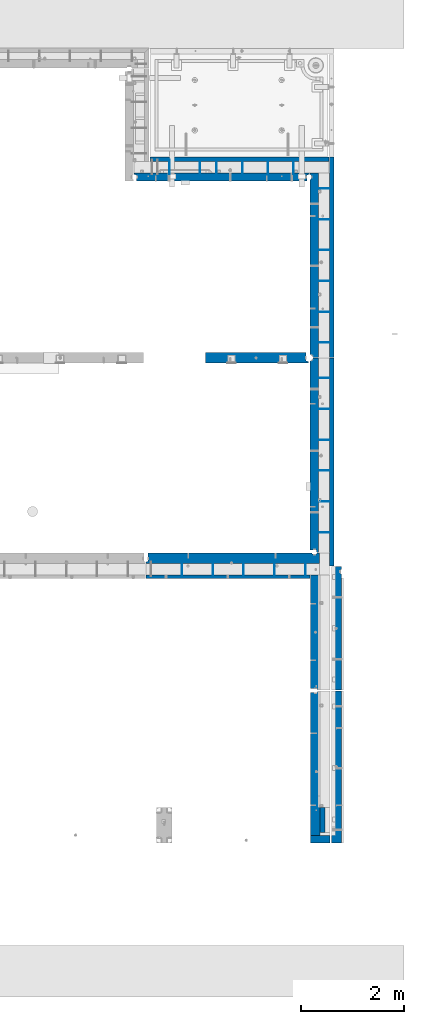
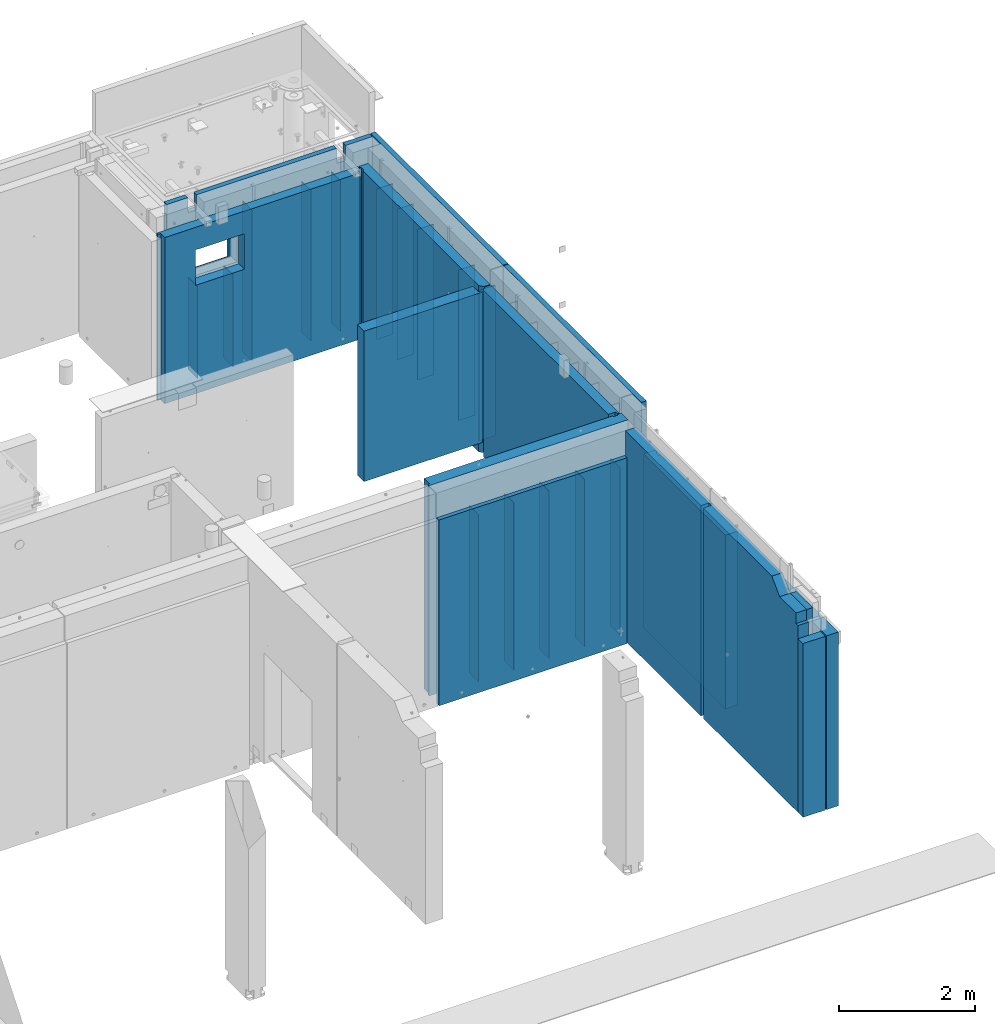
# One storey, part 178 of 264: 38 walls, 9 elements without a shape of their own.
"""IFC2X3 building model written with IfcOpenShell, lengths in millimetres."""

from ifc_helpers import new_model, si_unit, frame, origin_with_axes, place, context, subcontext, project, spatial, faceted_brep, material, type_object, element, aggregate, save


model = new_model("IFC2X3")

# Units and contexts
model_context = context("Model", 3, precision=1e-05, world=origin_with_axes())
body_context = subcontext(model_context, "Body", "Model", "MODEL_VIEW")
ifc_project = project(units=[si_unit("LENGTHUNIT", "METRE", prefix="MILLI"), si_unit("AREAUNIT", "SQUARE_METRE"), si_unit("VOLUMEUNIT", "CUBIC_METRE"), si_unit("MASSUNIT", "GRAM", prefix="KILO"), si_unit("TIMEUNIT", "SECOND"), si_unit("PLANEANGLEUNIT", "RADIAN"), si_unit("SOLIDANGLEUNIT", "STERADIAN"), si_unit("THERMODYNAMICTEMPERATUREUNIT", "DEGREE_CELSIUS"), si_unit("LUMINOUSINTENSITYUNIT", "LUMEN")], contexts=[model_context])

# Site, building, storey
site_placement = place(None, origin_with_axes())
site = spatial("IfcSite", under=ifc_project, at=site_placement, CompositionType="ELEMENT")
building_placement = place(site_placement, origin_with_axes())
building = spatial("IfcBuilding", under=site, at=building_placement, CompositionType="ELEMENT")
storey_placement = place(building_placement, origin_with_axes())
storey = spatial("IfcBuildingStorey", under=building, at=storey_placement, Name="K", CompositionType="ELEMENT", Elevation=0.0)

# Assembly, walls
assembly_1_placement = place(storey_placement, origin_with_axes())
assembly_1 = element("IfcElementAssembly", 1, at=assembly_1_placement, inside=storey, AssemblyPlace="NOTDEFINED", PredefinedType="REINFORCEMENT_UNIT")
ifc_material_1 = material(Name="Undefined")
wall_type_1 = type_object("IfcWallType", PredefinedType="NOTDEFINED")
wall_1_placement = place(assembly_1_placement, frame((32405.0062229193, 12730.0010506694, 79360.0), z_axis=(0.0, 0.0, 1.0), x_axis=(0.0, 1.0, 0.0)))
wall_1 = element("IfcWall", 2, at=wall_1_placement, type_object=wall_type_1, material=ifc_material_1, Name="(PD)", context=body_context, shape_type="Brep", body=[
    faceted_brep([(0.0, 4.99999999999909, -1500.0), (0.0, 4.99999999999909, 1500.0), (280.000000000024, 5.0, 1500.0), (280.000000000024, 5.0, -1500.0), (0.0, -5.00000000000091, 1500.0), (280.000000000025, -5.0, 1500.0), (0.0, -5.00000000000091, -1500.0), (280.000000000025, -5.0, -1500.0)], [[[0, 1, 2, 3]], [[1, 4, 5, 2]], [[4, 6, 7, 5]], [[6, 0, 3, 7]], [[5, 7, 3, 2]], [[6, 4, 1, 0]]]),
])
wall_2_placement = place(assembly_1_placement, frame((33005.0062229194, 12730.0010506694, 79360.0), z_axis=(0.0, 0.0, 1.0), x_axis=(0.0, 1.0, 0.0)))
wall_2 = element("IfcWall", 3, at=wall_2_placement, type_object=wall_type_1, material=ifc_material_1, Name="(PD)", context=body_context, shape_type="Brep", body=[
    faceted_brep([(0.0, 4.99999999999909, -1500.0), (0.0, 4.99999999999909, 1500.0), (280.000000000024, 5.0, 1500.0), (280.000000000024, 5.0, -1500.0), (0.0, -5.00000000000091, 1500.0), (280.000000000025, -5.0, 1500.0), (0.0, -5.00000000000091, -1500.0), (280.000000000025, -5.0, -1500.0)], [[[0, 1, 2, 3]], [[1, 4, 5, 2]], [[4, 6, 7, 5]], [[6, 0, 3, 7]], [[5, 7, 3, 2]], [[6, 4, 1, 0]]]),
])
wall_3_placement = place(assembly_1_placement, frame((33605.0062229194, 12730.0010506694, 79360.0), z_axis=(0.0, 0.0, 1.0), x_axis=(0.0, 1.0, 0.0)))
wall_3 = element("IfcWall", 4, at=wall_3_placement, type_object=wall_type_1, material=ifc_material_1, Name="(PD)", context=body_context, shape_type="Brep", body=[
    faceted_brep([(0.0, 4.99999999999909, -1500.0), (0.0, 4.99999999999909, 1500.0), (280.000000000024, 5.0, 1500.0), (280.000000000024, 5.0, -1500.0), (0.0, -5.00000000000091, 1500.0), (280.000000000025, -5.0, 1500.0), (0.0, -5.00000000000091, -1500.0), (280.000000000025, -5.0, -1500.0)], [[[0, 1, 2, 3]], [[1, 4, 5, 2]], [[4, 6, 7, 5]], [[6, 0, 3, 7]], [[5, 7, 3, 2]], [[6, 4, 1, 0]]]),
])
wall_4_placement = place(assembly_1_placement, frame((34205.0062229194, 12730.0010506694, 79360.0), z_axis=(0.0, 0.0, 1.0), x_axis=(0.0, 1.0, 0.0)))
wall_4 = element("IfcWall", 5, at=wall_4_placement, type_object=wall_type_1, material=ifc_material_1, Name="(PD)", context=body_context, shape_type="Brep", body=[
    faceted_brep([(0.0, 4.99999999999909, -1500.0), (0.0, 4.99999999999909, 1500.0), (280.000000000024, 5.0, 1500.0), (280.000000000024, 5.0, -1500.0), (0.0, -5.00000000000091, 1500.0), (280.000000000025, -5.0, 1500.0), (0.0, -5.00000000000091, -1500.0), (280.000000000025, -5.0, -1500.0)], [[[0, 1, 2, 3]], [[1, 4, 5, 2]], [[4, 6, 7, 5]], [[6, 0, 3, 7]], [[5, 7, 3, 2]], [[6, 4, 1, 0]]]),
])
wall_5_placement = place(assembly_1_placement, frame((34805.0062229194, 12730.0010506694, 79360.0), z_axis=(0.0, 0.0, 1.0), x_axis=(0.0, 1.0, 0.0)))
wall_5 = element("IfcWall", 6, at=wall_5_placement, type_object=wall_type_1, material=ifc_material_1, Name="(PD)", context=body_context, shape_type="Brep", body=[
    faceted_brep([(0.0, 4.99999999999909, -1500.0), (0.0, 4.99999999999909, 1500.0), (280.000000000024, 5.0, 1500.0), (280.000000000024, 5.0, -1500.0), (0.0, -5.00000000000091, 1500.0), (280.000000000025, -5.0, 1500.0), (0.0, -5.00000000000091, -1500.0), (280.000000000025, -5.0, -1500.0)], [[[0, 1, 2, 3]], [[1, 4, 5, 2]], [[4, 6, 7, 5]], [[6, 0, 3, 7]], [[5, 7, 3, 2]], [[6, 4, 1, 0]]]),
])

# Assembly, wall
assembly_2_placement = place(storey_placement, origin_with_axes())
assembly_2 = element("IfcElementAssembly", 7, at=assembly_2_placement, inside=storey, AssemblyPlace="NOTDEFINED", PredefinedType="REINFORCEMENT_UNIT")
ifc_material_2 = material(Name="CONCRETE/C30/37")
wall_type_2 = type_object("IfcWallType", PredefinedType="NOTDEFINED")
wall_6_placement = place(assembly_2_placement, frame((35140.0024573139, 8230.00189658467, 79470.0), z_axis=(0.0, 0.0, 1.0), x_axis=(0.0, -1.0, 0.0)))
wall_6 = element("IfcWall", 8, at=wall_6_placement, type_object=wall_type_2, material=ifc_material_2, context=body_context, shape_type="Brep", body=[
    faceted_brep([(0.0, 50.0, -1770.0), (0.0, 50.0, 1770.0), (479.99999999992, 50.0, 1770.0), (479.99999999992, 50.0, -1770.0), (0.0, -50.0, 1770.0), (479.99999999992, -50.0, 1770.0), (0.0, -50.0, -1770.0), (479.99999999992, -50.0, -1770.0)], [[[0, 1, 2, 3]], [[1, 4, 5, 2]], [[4, 6, 7, 5]], [[6, 0, 3, 7]], [[5, 7, 3, 2]], [[6, 4, 1, 0]]]),
])

assembly_3_placement = place(storey_placement, origin_with_axes())
assembly_3 = element("IfcElementAssembly", 9, at=assembly_3_placement, inside=storey, AssemblyPlace="NOTDEFINED", PredefinedType="REINFORCEMENT_UNIT")
ifc_material_3 = material(Name="CONCRETE/C35/45")
wall_type_3 = type_object("IfcWallType", PredefinedType="NOTDEFINED")
wall_7_placement = place(assembly_3_placement, frame((35410.0000014901, 10499.9996549055, 79257.5030770672), z_axis=(0.0, 0.0, 1.0), x_axis=(0.0, -1.0, 0.0)))
wall_7 = element("IfcWall", 10, at=wall_7_placement, type_object=wall_type_3, material=ifc_material_3, context=body_context, shape_type="Brep", body=[
    faceted_brep([(0.0, 100.0, -1557.5), (0.0, 100.0, 1557.5), (2954.98965490548, 100.0, 1557.5), (2954.98965490548, 100.0, -1557.5), (0.0, -100.0, 1557.5), (2954.98965490548, -100.0, 1557.5), (0.0, -100.0, -1557.5), (2954.98965490548, -100.0, -1557.5)], [[[0, 1, 2, 3]], [[1, 4, 5, 2]], [[4, 6, 7, 5]], [[6, 0, 3, 7]], [[5, 7, 3, 2]], [[6, 4, 1, 0]]]),
])
aggregate(assembly_3, [wall_7])

assembly_4_placement = place(storey_placement, origin_with_axes())
assembly_4 = element("IfcElementAssembly", 11, at=assembly_4_placement, inside=storey, AssemblyPlace="NOTDEFINED", PredefinedType="REINFORCEMENT_UNIT")
wall_8_placement = place(assembly_4_placement, frame((35410.0000014901, 12919.9896549055, 79257.5030770672), z_axis=(0.0, 0.0, 1.0), x_axis=(0.0, -1.0, 0.0)))
wall_8 = element("IfcWall", 12, at=wall_8_placement, type_object=wall_type_3, material=ifc_material_3, context=body_context, shape_type="Brep", body=[
    faceted_brep([(149.999653415372, 100.0, 1557.5), (149.999653415372, 100.0, -1557.5), (136.999653415371, 80.0, -1557.5), (136.999653415371, 80.0, 1557.5), (62.9996534153706, 80.0, -1557.5), (62.9996534153706, 80.0, 1557.5), (49.999653415367, 100.0, 1557.5), (49.999653415367, 100.0, -1557.5), (2404.98965490548, -100.0, 1557.5), (2404.98965490548, -100.0, -1557.5), (2404.98965490548, 100.0, -1557.5), (2404.98965490548, 100.0, 1557.5), (-0.000346584629369318, -100.0, 1557.5), (-0.000346584629369318, -100.0, -1557.5), (-0.000346584629369318, 100.0, 1557.5), (-0.000346584629369318, 100.0, -1557.5)], [[[0, 1, 2, 3]], [[3, 2, 4, 5]], [[6, 5, 4, 7]], [[8, 9, 10, 11]], [[12, 13, 9, 8]], [[13, 12, 14, 15]], [[15, 14, 6, 7]], [[2, 1, 10, 9, 13, 15, 7, 4]], [[11, 10, 1, 0]], [[14, 12, 8, 11, 0, 3, 5, 6]]]),
])
aggregate(assembly_4, [wall_8])

# Assembly, walls
assembly_5_placement = place(storey_placement, origin_with_axes())
assembly_5 = element("IfcElementAssembly", 13, at=assembly_5_placement, inside=storey, AssemblyPlace="NOTDEFINED", PredefinedType="REINFORCEMENT_UNIT")
wall_type_4 = type_object("IfcWallType", PredefinedType="NOTDEFINED")
wall_9_placement = place(assembly_5_placement, frame((32759.9902441406, 20549.9951872276, 79465.0), z_axis=(0.0, 0.0, 1.0), x_axis=(0.0, 1.0, 0.0)))
wall_9 = element("IfcWall", 14, at=wall_9_placement, type_object=wall_type_4, material=ifc_material_1, Name="(PD)", context=body_context, shape_type="Brep", body=[
    faceted_brep([(0.0, 5.0, -825.0), (0.0, 5.0, 825.0), (280.0, 5.0, 825.0), (280.0, 5.0, -825.0), (0.0, -5.0, 825.0), (280.0, -5.0, 825.0), (0.0, -5.0, -825.0), (280.0, -5.0, -825.0)], [[[0, 1, 2, 3]], [[1, 4, 5, 2]], [[4, 6, 7, 5]], [[6, 0, 3, 7]], [[5, 7, 3, 2]], [[6, 4, 1, 0]]]),
])
wall_10_placement = place(assembly_5_placement, frame((32159.9902441406, 20549.9951872276, 79465.0), z_axis=(0.0, 0.0, 1.0), x_axis=(0.0, 1.0, 0.0)))
wall_10 = element("IfcWall", 15, at=wall_10_placement, type_object=wall_type_4, material=ifc_material_1, Name="(PD)", context=body_context, shape_type="Brep", body=[
    faceted_brep([(0.0, 5.0, -825.0), (0.0, 5.0, 825.0), (280.0, 5.0, 825.0), (280.0, 5.0, -825.0), (0.0, -5.0, 825.0), (280.0, -5.0, 825.0), (0.0, -5.0, -825.0), (280.0, -5.0, -825.0)], [[[0, 1, 2, 3]], [[1, 4, 5, 2]], [[4, 6, 7, 5]], [[6, 0, 3, 7]], [[5, 7, 3, 2]], [[6, 4, 1, 0]]]),
])
wall_type_5 = type_object("IfcWallType", PredefinedType="NOTDEFINED")
wall_11_placement = place(assembly_5_placement, frame((34579.9902441406, 20549.9951872276, 79990.0), z_axis=(0.0, 0.0, 1.0), x_axis=(0.0, 1.0, 0.0)))
wall_11 = element("IfcWall", 16, at=wall_11_placement, type_object=wall_type_5, material=ifc_material_1, Name="(PD)", context=body_context, shape_type="Brep", body=[
    faceted_brep([(0.0, 5.0, -1350.0), (0.0, 5.0, 1350.0), (280.0, 5.0, 1350.0), (280.0, 5.0, -1350.0), (0.0, -5.0, 1350.0), (280.0, -5.0, 1350.0), (0.0, -5.0, -1350.0), (280.0, -5.0, -1350.0)], [[[0, 1, 2, 3]], [[1, 4, 5, 2]], [[4, 6, 7, 5]], [[6, 0, 3, 7]], [[5, 7, 3, 2]], [[6, 4, 1, 0]]]),
])
wall_12_placement = place(assembly_5_placement, frame((34079.9902441406, 20549.9951872276, 79990.0), z_axis=(0.0, 0.0, 1.0), x_axis=(0.0, 1.0, 0.0)))
wall_12 = element("IfcWall", 17, at=wall_12_placement, type_object=wall_type_5, material=ifc_material_1, Name="(PD)", context=body_context, shape_type="Brep", body=[
    faceted_brep([(0.0, 5.0, -1350.0), (0.0, 5.0, 1350.0), (280.0, 5.0, 1350.0), (280.0, 5.0, -1350.0), (0.0, -5.0, 1350.0), (280.0, -5.0, 1350.0), (0.0, -5.0, -1350.0), (280.0, -5.0, -1350.0)], [[[0, 1, 2, 3]], [[1, 4, 5, 2]], [[4, 6, 7, 5]], [[6, 0, 3, 7]], [[5, 7, 3, 2]], [[6, 4, 1, 0]]]),
])
wall_13_placement = place(assembly_5_placement, frame((33579.9902441406, 20549.9951872276, 79990.0), z_axis=(0.0, 0.0, 1.0), x_axis=(0.0, 1.0, 0.0)))
wall_13 = element("IfcWall", 18, at=wall_13_placement, type_object=wall_type_5, material=ifc_material_1, Name="(PD)", context=body_context, shape_type="Brep", body=[
    faceted_brep([(0.0, 5.0, -1350.0), (0.0, 5.0, 1350.0), (280.0, 5.0, 1350.0), (280.0, 5.0, -1350.0), (0.0, -5.0, 1350.0), (280.0, -5.0, 1350.0), (0.0, -5.0, -1350.0), (280.0, -5.0, -1350.0)], [[[0, 1, 2, 3]], [[1, 4, 5, 2]], [[4, 6, 7, 5]], [[6, 0, 3, 7]], [[5, 7, 3, 2]], [[6, 4, 1, 0]]]),
])

assembly_6_placement = place(storey_placement, origin_with_axes())
assembly_6 = element("IfcElementAssembly", 19, at=assembly_6_placement, inside=storey, AssemblyPlace="NOTDEFINED", PredefinedType="REINFORCEMENT_UNIT")
wall_14_placement = place(assembly_6_placement, frame((35310.0033032291, 13584.9956621903, 79990.0), z_axis=(0.0, 0.0, 1.0), x_axis=(-1.0, 3.00000001838171e-08, 0.0)))
wall_14 = element("IfcWall", 20, at=wall_14_placement, type_object=wall_type_5, material=ifc_material_1, Name="(PD)", context=body_context, shape_type="Brep", body=[
    faceted_brep([(0.0, 5.0, -1350.0), (0.0, 5.0, 1350.0), (280.0, 5.0, 1350.0), (280.0, 5.0, -1350.0), (0.0, -5.0, 1350.0), (280.0, -5.0, 1350.0), (0.0, -5.0, -1350.0), (280.0, -5.0, -1350.0)], [[[0, 1, 2, 3]], [[1, 4, 5, 2]], [[4, 6, 7, 5]], [[6, 0, 3, 7]], [[5, 7, 3, 2]], [[6, 4, 1, 0]]]),
])
wall_15_placement = place(assembly_6_placement, frame((35310.0033032291, 14184.9956621903, 79990.0), z_axis=(0.0, 0.0, 1.0), x_axis=(-1.0, 3.00000001838171e-08, 0.0)))
wall_15 = element("IfcWall", 21, at=wall_15_placement, type_object=wall_type_5, material=ifc_material_1, Name="(PD)", context=body_context, shape_type="Brep", body=[
    faceted_brep([(0.0, 5.0, -1350.0), (0.0, 5.0, 1350.0), (280.0, 5.0, 1350.0), (280.0, 5.0, -1350.0), (0.0, -5.0, 1350.0), (280.0, -5.0, 1350.0), (0.0, -5.0, -1350.0), (280.0, -5.0, -1350.0)], [[[0, 1, 2, 3]], [[1, 4, 5, 2]], [[4, 6, 7, 5]], [[6, 0, 3, 7]], [[5, 7, 3, 2]], [[6, 4, 1, 0]]]),
])
wall_16_placement = place(assembly_6_placement, frame((35310.0033032291, 14784.9956621903, 79990.0), z_axis=(0.0, 0.0, 1.0), x_axis=(-1.0, 3.00000001838171e-08, 0.0)))
wall_16 = element("IfcWall", 22, at=wall_16_placement, type_object=wall_type_5, material=ifc_material_1, Name="(PD)", context=body_context, shape_type="Brep", body=[
    faceted_brep([(0.0, 5.0, -1350.0), (0.0, 5.0, 1350.0), (280.0, 5.0, 1350.0), (280.0, 5.0, -1350.0), (0.0, -5.0, 1350.0), (280.0, -5.0, 1350.0), (0.0, -5.0, -1350.0), (280.0, -5.0, -1350.0)], [[[0, 1, 2, 3]], [[1, 4, 5, 2]], [[4, 6, 7, 5]], [[6, 0, 3, 7]], [[5, 7, 3, 2]], [[6, 4, 1, 0]]]),
])
wall_17_placement = place(assembly_6_placement, frame((35310.0033032291, 15384.9956621903, 79990.0), z_axis=(0.0, 0.0, 1.0), x_axis=(-1.0, 3.00000001838171e-08, 0.0)))
wall_17 = element("IfcWall", 23, at=wall_17_placement, type_object=wall_type_5, material=ifc_material_1, Name="(PD)", context=body_context, shape_type="Brep", body=[
    faceted_brep([(0.0, 5.0, -1350.0), (0.0, 5.0, 1350.0), (280.0, 5.0, 1350.0), (280.0, 5.0, -1350.0), (0.0, -5.0, 1350.0), (280.0, -5.0, 1350.0), (0.0, -5.0, -1350.0), (280.0, -5.0, -1350.0)], [[[0, 1, 2, 3]], [[1, 4, 5, 2]], [[4, 6, 7, 5]], [[6, 0, 3, 7]], [[5, 7, 3, 2]], [[6, 4, 1, 0]]]),
])
wall_18_placement = place(assembly_6_placement, frame((35310.0033032291, 15984.9956621903, 79990.0), z_axis=(0.0, 0.0, 1.0), x_axis=(-1.0, 3.00000001838171e-08, 0.0)))
wall_18 = element("IfcWall", 24, at=wall_18_placement, type_object=wall_type_5, material=ifc_material_1, Name="(PD)", context=body_context, shape_type="Brep", body=[
    faceted_brep([(0.0, 5.0, -1350.0), (0.0, 5.0, 1350.0), (280.0, 5.0, 1350.0), (280.0, 5.0, -1350.0), (0.0, -5.0, 1350.0), (280.0, -5.0, 1350.0), (0.0, -5.0, -1350.0), (280.0, -5.0, -1350.0)], [[[0, 1, 2, 3]], [[1, 4, 5, 2]], [[4, 6, 7, 5]], [[6, 0, 3, 7]], [[5, 7, 3, 2]], [[6, 4, 1, 0]]]),
])
wall_19_placement = place(assembly_6_placement, frame((35310.0033032291, 16584.9956621903, 79990.0), z_axis=(0.0, 0.0, 1.0), x_axis=(-1.0, 3.00000001838171e-08, 0.0)))
wall_19 = element("IfcWall", 25, at=wall_19_placement, type_object=wall_type_5, material=ifc_material_1, Name="(PD)", context=body_context, shape_type="Brep", body=[
    faceted_brep([(0.0, 5.0, -1350.0), (0.0, 5.0, 1350.0), (280.0, 5.0, 1350.0), (280.0, 5.0, -1350.0), (0.0, -5.0, 1350.0), (280.0, -5.0, 1350.0), (0.0, -5.0, -1350.0), (280.0, -5.0, -1350.0)], [[[0, 1, 2, 3]], [[1, 4, 5, 2]], [[4, 6, 7, 5]], [[6, 0, 3, 7]], [[5, 7, 3, 2]], [[6, 4, 1, 0]]]),
])

assembly_7_placement = place(storey_placement, origin_with_axes())
assembly_7 = element("IfcElementAssembly", 26, at=assembly_7_placement, inside=storey, AssemblyPlace="NOTDEFINED", PredefinedType="REINFORCEMENT_UNIT")
wall_20_placement = place(assembly_7_placement, frame((35310.0033032291, 17274.9956621903, 79855.0), z_axis=(0.0, 0.0, 1.0), x_axis=(-1.0, 3.00000001838171e-08, 0.0)))
wall_20 = element("IfcWall", 27, at=wall_20_placement, type_object=wall_type_5, material=ifc_material_1, Name="(PD)", context=body_context, shape_type="Brep", body=[
    faceted_brep([(0.0, 5.0, -1350.0), (0.0, 5.0, 1350.0), (280.0, 5.0, 1350.0), (280.0, 5.0, -1350.0), (0.0, -5.0, 1350.0), (280.0, -5.0, 1350.0), (0.0, -5.0, -1350.0), (280.0, -5.0, -1350.0)], [[[0, 1, 2, 3]], [[1, 4, 5, 2]], [[4, 6, 7, 5]], [[6, 0, 3, 7]], [[5, 7, 3, 2]], [[6, 4, 1, 0]]]),
])
wall_21_placement = place(assembly_7_placement, frame((35310.0033032291, 17874.9956621903, 79855.0), z_axis=(0.0, 0.0, 1.0), x_axis=(-1.0, 3.00000001838171e-08, 0.0)))
wall_21 = element("IfcWall", 28, at=wall_21_placement, type_object=wall_type_5, material=ifc_material_1, Name="(PD)", context=body_context, shape_type="Brep", body=[
    faceted_brep([(0.0, 5.0, -1350.0), (0.0, 5.0, 1350.0), (280.0, 5.0, 1350.0), (280.0, 5.0, -1350.0), (0.0, -5.0, 1350.0), (280.0, -5.0, 1350.0), (0.0, -5.0, -1350.0), (280.0, -5.0, -1350.0)], [[[0, 1, 2, 3]], [[1, 4, 5, 2]], [[4, 6, 7, 5]], [[6, 0, 3, 7]], [[5, 7, 3, 2]], [[6, 4, 1, 0]]]),
])
wall_22_placement = place(assembly_7_placement, frame((35310.0033032291, 18474.9956621903, 79855.0), z_axis=(0.0, 0.0, 1.0), x_axis=(-1.0, 3.00000001838171e-08, 0.0)))
wall_22 = element("IfcWall", 29, at=wall_22_placement, type_object=wall_type_5, material=ifc_material_1, Name="(PD)", context=body_context, shape_type="Brep", body=[
    faceted_brep([(0.0, 5.0, -1350.0), (0.0, 5.0, 1350.0), (280.0, 5.0, 1350.0), (280.0, 5.0, -1350.0), (0.0, -5.0, 1350.0), (280.0, -5.0, 1350.0), (0.0, -5.0, -1350.0), (280.0, -5.0, -1350.0)], [[[0, 1, 2, 3]], [[1, 4, 5, 2]], [[4, 6, 7, 5]], [[6, 0, 3, 7]], [[5, 7, 3, 2]], [[6, 4, 1, 0]]]),
])
wall_23_placement = place(assembly_7_placement, frame((35310.0033032291, 19074.9956621903, 79855.0), z_axis=(0.0, 0.0, 1.0), x_axis=(-1.0, 3.00000001838171e-08, 0.0)))
wall_23 = element("IfcWall", 30, at=wall_23_placement, type_object=wall_type_5, material=ifc_material_1, Name="(PD)", context=body_context, shape_type="Brep", body=[
    faceted_brep([(0.0, 5.0, -1350.0), (0.0, 5.0, 1350.0), (280.0, 5.0, 1350.0), (280.0, 5.0, -1350.0), (0.0, -5.0, 1350.0), (280.0, -5.0, 1350.0), (0.0, -5.0, -1350.0), (280.0, -5.0, -1350.0)], [[[0, 1, 2, 3]], [[1, 4, 5, 2]], [[4, 6, 7, 5]], [[6, 0, 3, 7]], [[5, 7, 3, 2]], [[6, 4, 1, 0]]]),
])
wall_24_placement = place(assembly_7_placement, frame((35310.0033032291, 19674.9956621903, 79855.0), z_axis=(0.0, 0.0, 1.0), x_axis=(-1.0, 3.00000001838171e-08, 0.0)))
wall_24 = element("IfcWall", 31, at=wall_24_placement, type_object=wall_type_5, material=ifc_material_1, Name="(PD)", context=body_context, shape_type="Brep", body=[
    faceted_brep([(0.0, 5.0, -1350.0), (0.0, 5.0, 1350.0), (280.0, 5.0, 1350.0), (280.0, 5.0, -1350.0), (0.0, -5.0, 1350.0), (280.0, -5.0, 1350.0), (0.0, -5.0, -1350.0), (280.0, -5.0, -1350.0)], [[[0, 1, 2, 3]], [[1, 4, 5, 2]], [[4, 6, 7, 5]], [[6, 0, 3, 7]], [[5, 7, 3, 2]], [[6, 4, 1, 0]]]),
])
wall_25_placement = place(assembly_7_placement, frame((35310.0033032291, 20274.9956621903, 79855.0), z_axis=(0.0, 0.0, 1.0), x_axis=(-1.0, 3.00000001838171e-08, 0.0)))
wall_25 = element("IfcWall", 32, at=wall_25_placement, type_object=wall_type_5, material=ifc_material_1, Name="(PD)", context=body_context, shape_type="Brep", body=[
    faceted_brep([(0.0, 5.0, -1350.0), (0.0, 5.0, 1350.0), (280.0, 5.0, 1350.0), (280.0, 5.0, -1350.0), (0.0, -5.0, 1350.0), (280.0, -5.0, 1350.0), (0.0, -5.0, -1350.0), (280.0, -5.0, -1350.0)], [[[0, 1, 2, 3]], [[1, 4, 5, 2]], [[4, 6, 7, 5]], [[6, 0, 3, 7]], [[5, 7, 3, 2]], [[6, 4, 1, 0]]]),
])

# Wall
wall_26_placement = place(assembly_5_placement, frame((33079.9902441406, 20549.9951872276, 79990.0), z_axis=(0.0, 0.0, 1.0), x_axis=(0.0, 1.0, 0.0)))
wall_26 = element("IfcWall", 33, at=wall_26_placement, type_object=wall_type_5, material=ifc_material_1, Name="(PD)", context=body_context, shape_type="Brep", body=[
    faceted_brep([(0.0, 5.0, -1350.0), (0.0, 5.0, 1350.0), (280.0, 5.0, 1350.0), (280.0, 5.0, -1350.0), (0.0, -5.0, 1350.0), (280.0, -5.0, 1350.0), (0.0, -5.0, -1350.0), (280.0, -5.0, -1350.0)], [[[0, 1, 2, 3]], [[1, 4, 5, 2]], [[4, 6, 7, 5]], [[6, 0, 3, 7]], [[5, 7, 3, 2]], [[6, 4, 1, 0]]]),
])

wall_type_6 = type_object("IfcWallType", PredefinedType="NOTDEFINED")
wall_27_placement = place(assembly_6_placement, frame((35322.5000031936, 16975.0005124534, 80115.0), z_axis=(0.0, 0.0, 1.0), x_axis=(0.0, -1.0, 0.0)))
wall_27 = element("IfcWall", 34, at=wall_27_placement, type_object=wall_type_6, material=ifc_material_2, context=body_context, shape_type="Brep", body=[
    faceted_brep([(0.000294195302558364, 42.5000000000073, -1625.0), (0.000294195302558364, 42.5000000000073, 1625.0), (4040.00844965085, 42.5000000000073, 1625.0), (4040.00844965085, 42.5000000000073, -1625.0), (0.000242430302023422, -42.5, 1625.0), (4040.00844965085, -42.4999999999927, 1625.0), (0.000242430302023422, -42.5, -1625.0), (4040.00844965085, -42.4999999999927, -1625.0)], [[[0, 1, 2, 3]], [[1, 4, 5, 2]], [[4, 6, 7, 5]], [[6, 0, 3, 7]], [[5, 7, 3, 2]], [[6, 4, 1, 0]]]),
])

wall_28_placement = place(assembly_7_placement, frame((35322.5, 20885.0, 80115.0), z_axis=(0.0, 0.0, 1.0), x_axis=(0.0, -1.0, 0.0)))
wall_28 = element("IfcWall", 35, at=wall_28_placement, type_object=wall_type_6, material=ifc_material_2, context=body_context, shape_type="Brep", body=[
    faceted_brep([(0.0, 42.5000000000036, -1625.0), (0.0, 42.5000000000036, 1625.0), (3894.99975585938, 42.5, 1625.0), (3894.99975585938, 42.5, -1625.0), (3.63797880709171e-12, -42.4999999999964, 1625.0), (3894.99975585938, -42.5, 1625.0), (3.63797880709171e-12, -42.4999999999964, -1625.0), (3894.99975585938, -42.5, -1625.0)], [[[0, 1, 2, 3]], [[1, 4, 5, 2]], [[4, 6, 7, 5]], [[6, 0, 3, 7]], [[5, 7, 3, 2]], [[6, 4, 1, 0]]]),
])

wall_29_placement = place(assembly_5_placement, frame((31779.9952566975, 20842.5, 80115.0), z_axis=(0.0, 0.0, 1.0), x_axis=(1.0, 0.0, 0.0)))
wall_29 = element("IfcWall", 36, at=wall_29_placement, type_object=wall_type_6, material=ifc_material_2, context=body_context, shape_type="Brep", body=[
    faceted_brep([(2879.97819479133, 42.5, 1625.0), (2879.97819479133, -42.5, 1625.0), (2879.97819479133, -42.5, 1355.0), (2879.97819479133, 42.5, 1355.0), (3029.97819479133, -42.5, 1355.0), (3029.97819479133, 42.5, 1355.0), (3029.97819479133, 42.5, 1625.0), (3029.97819479133, -42.5, 1625.0), (504.978194791329, 42.5, 1625.0), (504.978194791329, -42.5, 1625.0), (504.978194791329, 42.5, 1355.0), (504.978194791329, -42.5, 1355.0), (354.978194791329, 42.5, 1355.0), (354.978194791329, -42.5, 1355.0), (354.978194791329, 42.5, 1625.0), (354.978194791329, -42.5, 1625.0), (0.0, 42.5000000000036, 1625.0), (3.63797880709171e-12, -42.4999999999964, 1625.0), (3.63797880709171e-12, -42.4999999999964, -1625.0), (0.0, 42.5000000000036, -1625.0), (3485.00474330254, 42.5, -1625.0), (3485.00474330254, -42.5, -1625.0), (3485.00474330254, -42.5, 1625.0), (3485.00474330254, 42.5, 1625.0), (1055.00306334562, -42.5, 325.0), (305.003063345623, -42.5, 325.0), (305.003063345623, -42.5, 915.0), (305.003063345623, -42.5, 920.0), (1055.00306334562, -42.5, 920.0), (1055.00306334562, -42.5, 915.0), (1065.00306334562, 42.5, 275.0), (1065.00306334562, 42.5, 915.0), (295.003063345623, 42.5, 275.0), (295.003063345623, 42.5, 915.0), (305.003063345623, 42.5, 915.0), (1055.00306334562, 42.5, 915.0)], [[[0, 1, 2, 3]], [[3, 2, 4, 5]], [[6, 5, 4, 7]], [[8, 9, 1, 0]], [[8, 10, 11, 9]], [[12, 13, 11, 10]], [[14, 15, 13, 12]], [[16, 17, 15, 14]], [[18, 17, 16, 19]], [[18, 19, 20, 21]], [[22, 21, 20, 23]], [[22, 23, 6, 7]], [[2, 1, 9, 11, 13, 15, 17, 18, 21, 22, 7, 4], [24, 25, 26, 27, 28, 29]], [[30, 24, 29, 28, 31]], [[32, 25, 24, 30]], [[26, 25, 32, 33, 27]], [[34, 35, 31, 28, 27, 33]], [[23, 20, 19, 16, 14, 12, 10, 8, 0, 3, 5, 6], [34, 33, 32, 30, 31, 35]]]),
])

ifc_material_4 = material(Name="CONCRETE/C25/30")
wall_type_7 = type_object("IfcWallType", PredefinedType="NOTDEFINED")
wall_30_placement = place(assembly_6_placement, frame((34980.0, 16980.0000452669, 79980.0), z_axis=(0.0, 0.0, 1.0), x_axis=(0.0, -1.0, 0.0)))
wall_30 = element("IfcWall", 37, at=wall_30_placement, type_object=wall_type_7, material=ifc_material_4, context=body_context, shape_type="Brep", body=[
    faceted_brep([(3734.99809692287, -80.0, 1490.0), (3734.99809692287, -80.0, -1490.0), (3734.9981726219, 37.0000420547076, -1490.0), (3734.9981726219, 37.0000420547076, 1490.0), (3784.99818103289, 50.0000097047014, 1490.0), (3784.99818103289, 50.0000097047014, -1490.0), (4.99978818623276, -20.0000000450164, 1490.0), (4.99978818623276, -20.0000000450164, -1490.0), (64.9997493662195, -80.0, -1490.0), (64.9997493662195, -80.0, 1490.0), (4.99985288623066, 80.0000000000073, 1490.0), (4.99985288623066, 80.0000000000073, -1490.0), (3784.99820044288, 80.0000000000146, 1490.0), (3784.99820044288, 80.0000000000146, -1490.0)], [[[0, 1, 2, 3]], [[4, 3, 2, 5]], [[6, 7, 8, 9]], [[10, 11, 7, 6]], [[11, 10, 12, 13]], [[13, 12, 4, 5]], [[1, 8, 7, 11, 13, 5, 2]], [[9, 8, 1, 0]], [[12, 10, 6, 9, 0, 3, 4]]]),
])

aggregate(assembly_6, [wall_14, wall_15, wall_16, wall_17, wall_18, wall_19, wall_27, wall_30])

wall_31_placement = place(assembly_7_placement, frame((34980.0, 20575.0, 79980.0), z_axis=(0.0, 0.0, 1.0), x_axis=(0.0, -1.0, 0.0)))
wall_31 = element("IfcWall", 38, at=wall_31_placement, type_object=wall_type_7, material=ifc_material_4, context=body_context, shape_type="Brep", body=[
    faceted_brep([(117.0, -60.0, 1490.0), (117.0, -60.0, -1490.0), (130.0, -80.0, -1490.0), (130.0, -80.0, 1490.0), (43.0, -60.0, 1490.0), (43.0, -60.0, -1490.0), (29.9999816127165, -80.0, 1490.0), (29.9999816127165, -80.0, -1490.0), (0.0, -80.0, -1490.0), (0.0, -80.0, 1490.0), (3.63797880709171e-12, 80.0000000000036, 1490.0), (3.63797880709171e-12, 80.0000000000036, -1490.0), (3584.99975585938, 80.0, 1490.0), (3584.99975585938, 80.0, -1490.0), (3584.99975585938, -20.0, 1490.0), (3584.99975585938, -20.0, -1490.0), (3524.99975585938, -80.0, 1490.0), (3524.99975585938, -80.0, -1490.0)], [[[0, 1, 2, 3]], [[4, 5, 1, 0]], [[6, 7, 5, 4]], [[8, 9, 10, 11]], [[11, 10, 12, 13]], [[13, 12, 14, 15]], [[14, 16, 17, 15]], [[17, 16, 3, 2]], [[8, 11, 13, 15, 17, 2, 1, 5, 7]], [[9, 8, 7, 6]], [[3, 16, 14, 12, 10, 9, 6, 4, 0]]]),
])

aggregate(assembly_7, [wall_20, wall_21, wall_22, wall_23, wall_24, wall_25, wall_28, wall_31])

wall_32_placement = place(assembly_5_placement, frame((31459.9951872276, 20500.0, 79980.0), z_axis=(0.0, 0.0, 1.0), x_axis=(1.0, 0.0, 0.0)))
wall_32 = element("IfcWall", 39, at=wall_32_placement, type_object=wall_type_7, material=ifc_material_4, context=body_context, shape_type="Brep", body=[
    faceted_brep([(3375.00481277244, -80.0, 1490.0), (3375.00481277244, -80.0, -1490.0), (3375.00481277244, 37.0, -1490.0), (3375.00481277244, 37.0, 1490.0), (15.0000853699057, 80.0, 1490.0), (15.0000853699057, 80.0, -1490.0), (15.0000694699011, 49.9999920500995, -1490.0), (15.0000694699011, 49.9999920500995, 1490.0), (3425.00481277244, 50.0, 1490.0), (3425.00481277244, 80.0, 1490.0), (65.0000625799075, 36.9999655501015, 1490.0), (65.0000005699258, -80.0, 1490.0), (65.0000625799075, 36.9999655501015, -1490.0), (65.0000005699258, -80.0, -1490.0), (3425.00481277244, 80.0, -1490.0), (3425.00481277244, 50.0, -1490.0), (585.003132815524, -80.0, 1085.0), (589.327457139847, 80.0, 1080.67567567568), (1410.6788084912, 80.0, 1080.67567567568), (1415.00313281552, -80.0, 1085.0), (589.327457139847, 80.0, 454.32432432432), (1410.6788084912, 80.0, 454.32432432432), (1415.00313281552, -80.0, 450.0), (585.003132815524, -80.0, 450.0)], [[[0, 1, 2, 3]], [[4, 5, 6, 7]], [[0, 3, 8, 9, 4, 7, 10, 11]], [[10, 12, 13, 11]], [[7, 6, 12, 10]], [[5, 14, 15, 2, 1, 13, 12, 6]], [[8, 3, 2, 15]], [[14, 9, 8, 15]], [[16, 17, 18, 19]], [[5, 4, 9, 14], [20, 21, 18, 17]], [[19, 18, 21, 22]], [[1, 0, 11, 13], [23, 16, 19, 22]], [[17, 16, 23, 20]], [[22, 21, 20, 23]]]),
])

aggregate(assembly_5, [wall_9, wall_10, wall_11, wall_12, wall_13, wall_26, wall_29, wall_32])

wall_type_8 = type_object("IfcWallType", PredefinedType="NOTDEFINED")
wall_33_placement = place(assembly_2_placement, frame((35290.0024573137, 7617.50189658477, 79257.5), z_axis=(0.0, 0.0, 1.0), x_axis=(-1.0, 3.00000001838171e-08, 0.0)))
wall_33 = element("IfcWall", 40, at=wall_33_placement, type_object=wall_type_8, material=ifc_material_2, context=body_context, shape_type="Brep", body=[
    faceted_brep([(0.0, 72.5, -1557.5), (0.0, 72.5, 1557.5), (380.0, 72.5, 1557.5), (380.0, 72.5, -1557.5), (0.0, -72.5, 1557.5), (380.0, -72.5, 1557.5), (0.0, -72.5, -1557.5), (380.0, -72.5, -1557.5)], [[[0, 1, 2, 3]], [[1, 4, 5, 2]], [[4, 6, 7, 5]], [[6, 0, 3, 7]], [[5, 7, 3, 2]], [[6, 4, 1, 0]]]),
])

wall_type_9 = type_object("IfcWallType", PredefinedType="NOTDEFINED")
wall_34_placement = place(assembly_1_placement, frame((34895.0024573137, 12725.0018965848, 79365.0), z_axis=(0.0, 0.0, 1.0), x_axis=(-1.0, 3.00000001838171e-08, 0.0)))
wall_34 = element("IfcWall", 41, at=wall_34_placement, type_object=wall_type_9, material=ifc_material_2, context=body_context, shape_type="Brep", body=[
    faceted_brep([(0.0, 35.0, -1665.0), (0.0, 35.0, 1665.0), (3185.0, 35.0, 1665.0), (3185.0, 35.0, -1665.0), (0.0, -35.0, 1665.0), (3185.0, -35.0, 1665.0), (0.0, -35.0, -1665.0), (3185.0, -35.0, -1665.0)], [[[0, 1, 2, 3]], [[1, 4, 5, 2]], [[4, 6, 7, 5]], [[6, 0, 3, 7]], [[5, 7, 3, 2]], [[6, 4, 1, 0]]]),
])

# Assembly, wall
assembly_8_placement = place(storey_placement, origin_with_axes())
assembly_8 = element("IfcElementAssembly", 42, at=assembly_8_placement, inside=storey, AssemblyPlace="NOTDEFINED", PredefinedType="REINFORCEMENT_UNIT")
wall_type_10 = type_object("IfcWallType", PredefinedType="NOTDEFINED")
wall_35_placement = place(assembly_8_placement, frame((32860.0, 16980.0002441406, 80122.5), z_axis=(0.0, 0.0, 1.0), x_axis=(1.0, 0.0, 0.0)))
wall_35 = element("IfcWall", 43, at=wall_35_placement, type_object=wall_type_10, material=ifc_material_4, context=body_context, shape_type="Brep", body=[
    faceted_brep([(1960.00000000001, 100.0, 1347.5), (1960.00000000001, -60.0, 1347.5), (1960.00000000001, -60.0, -1347.5), (1960.00000000001, 100.0, -1347.5), (2010.00000000001, -70.0, 1347.5), (2010.00000000001, -70.0, -1347.5), (0.0, -100.0, -1347.5), (0.0, -100.0, 1347.5), (0.0, 100.0, 1347.5), (0.0, 100.0, -1347.5), (2010.00000000001, -100.0, -1347.5), (2010.00000000001, -100.0, 1347.5)], [[[0, 1, 2, 3]], [[4, 5, 2, 1]], [[6, 7, 8, 9]], [[7, 6, 10, 11]], [[0, 8, 7, 11, 4, 1]], [[9, 8, 0, 3]], [[10, 6, 9, 3, 2, 5]], [[11, 10, 5, 4]]]),
])
aggregate(assembly_8, [wall_35])

# Wall
wall_type_11 = type_object("IfcWallType", PredefinedType="NOTDEFINED")
wall_36_placement = place(assembly_2_placement, frame((35000.0024573137, 10515.0018965848, 79585.0), z_axis=(0.0, 0.0, 1.0), x_axis=(0.0, -1.0, 0.0)))
wall_36 = element("IfcWall", 44, at=wall_36_placement, type_object=wall_type_11, material=ifc_material_2, context=body_context, shape_type="Brep", body=[
    faceted_brep([(93.7762919796533, 39.7017077833807, -778.792385753433), (93.7762919796533, -0.298292216619302, -778.792385753433), (93.7762919794095, -27.2982922166193, -740.608619569117), (93.7762919794095, 66.7017077833807, -740.608619569117), (45.0, 37.0, -827.568677733085), (45.0, -0.298292216619302, -827.56867773307), (38.7652897306489, 39.7017077833807, -833.80338800243), (45.0, -27.2982922166193, -789.384911548506), (15.0, 66.7017077833807, -819.384911548506), (45.0, 37.0, -789.384911548506), (15.0, 50.0, -819.384911548492), (15.0, 50.0, -843.004693210853), (2285.00207519531, -90.0, 1654.99999999987), (2055.0, -90.0, 1885.0), (45.0, -90.0, 1885.0), (45.0, -90.0, -1885.0), (2825.0, -90.0, -1885.0), (2825.0, -90.0, 1230.0), (2825.0, -90.0, 1465.0), (2765.0, -89.9999999999927, 1465.0), (2765.0, -90.0, 1654.99999999999), (15.0, 90.0, -1885.0), (2825.0, 90.0, -1885.0), (45.0, 37.0, -1885.0), (15.0, 50.0, -1885.0), (2825.0, 90.0, 1465.0), (2825.0, 90.0, 1230.0), (15.0, 90.0, 1885.0), (2055.0, 90.0, 1885.0), (2285.00207519531, 90.0, 1654.99999999987), (2765.0, 90.0, 1654.99999999996), (2765.0, 90.0000000000073, 1465.0), (15.0, 50.0, 1885.0), (45.0, 37.0, 1885.0)], [[[0, 1, 2, 3]], [[4, 5, 1, 0, 6]], [[7, 2, 1, 5]], [[8, 3, 2, 7, 9, 10]], [[11, 6, 0, 3, 8]], [[12, 13, 14, 15, 16, 17, 18, 19, 20]], [[21, 22, 16, 15, 23, 24]], [[25, 26, 22, 21, 27, 28, 29, 30, 31]], [[17, 16, 22, 26, 25, 18]], [[31, 19, 18, 25]], [[30, 20, 19, 31]], [[29, 12, 20, 30]], [[28, 13, 12, 29]], [[27, 32, 33, 14, 13, 28]], [[33, 32, 10, 9]], [[5, 4, 23, 15, 14, 33, 9, 7]], [[24, 23, 4, 6, 11]], [[32, 27, 21, 24, 11, 8, 10]]]),
])

aggregate(assembly_2, [wall_6, wall_33, wall_36])

# Assembly, wall
assembly_9_placement = place(storey_placement, origin_with_axes())
assembly_9 = element("IfcElementAssembly", 45, at=assembly_9_placement, inside=storey, AssemblyPlace="NOTDEFINED", PredefinedType="REINFORCEMENT_UNIT")
wall_37_placement = place(assembly_9_placement, frame((35000.0024573137, 12755.0018965848, 79585.0), z_axis=(0.0, 0.0, 1.0), x_axis=(0.0, -1.0, 0.0)))
wall_37 = element("IfcWall", 46, at=wall_37_placement, type_object=wall_type_11, material=ifc_material_2, context=body_context, shape_type="Brep", body=[
    faceted_brep([(2210.0, -90.0, 1885.0), (2210.0, -90.0, -1885.0), (2210.0, 37.0, -1885.0), (2210.0, 37.0, 1885.0), (2240.0, 50.0, 1885.0), (2240.0, 50.0, -1885.0), (0.0, -90.0, -1885.0), (0.0, -90.0, 1885.0), (0.0, 90.0, 1885.0), (0.0, 90.0, -1885.0), (2240.0, 90.0, 1885.0), (2240.0, 90.0, -1885.0)], [[[0, 1, 2, 3]], [[4, 3, 2, 5]], [[6, 7, 8, 9]], [[9, 8, 10, 11]], [[11, 10, 4, 5]], [[1, 6, 9, 11, 5, 2]], [[7, 6, 1, 0]], [[10, 8, 7, 0, 3, 4]]]),
])
aggregate(assembly_9, [wall_37])

# Wall
wall_type_12 = type_object("IfcWallType", PredefinedType="NOTDEFINED")
wall_38_placement = place(assembly_1_placement, frame((35085.0024573137, 13080.0018965848, 79585.0), z_axis=(0.0, 0.0, 1.0), x_axis=(-1.0, 3.00000001838171e-08, 0.0)))
wall_38 = element("IfcWall", 47, at=wall_38_placement, type_object=wall_type_12, material=ifc_material_4, context=body_context, shape_type="Brep", body=[
    faceted_brep([(141.99999830436, -79.9999993903839, 1885.0), (141.99999830436, -79.9999993903839, -1885.0), (154.999998714957, -100.0, -1885.0), (154.999998714957, -100.0, 1885.0), (67.9999982634326, -79.999997348632, 1885.0), (67.9999982634326, -79.999997348632, -1885.0), (54.9999989924254, -99.9999981312649, 1885.0), (54.9999989924254, -100.0, -1885.0), (3345.0, -100.0, 1885.0), (3345.0, -100.0, -1885.0), (3345.0, 57.0, -1885.0), (3345.0, 57.0, 1885.0), (3375.0, 70.0, -1885.0), (3375.0, 70.0, 1885.0), (3375.0, 100.0, -1885.0), (3375.0, 100.0, 1885.0), (0.0, 100.0, -1885.0), (0.0, 100.0, 1885.0), (0.0, -100.0, -1885.0), (0.0, -100.0, 1885.0)], [[[0, 1, 2, 3]], [[4, 5, 1, 0]], [[6, 7, 5, 4]], [[8, 9, 10, 11]], [[11, 10, 12, 13]], [[14, 15, 13, 12]], [[16, 17, 15, 14]], [[18, 19, 17, 16]], [[0, 3, 8, 11, 13, 15, 17, 19, 6, 4]], [[9, 8, 3, 2]], [[18, 16, 14, 12, 10, 9, 2, 1, 5, 7]], [[19, 18, 7, 6]]]),
])

aggregate(assembly_1, [wall_1, wall_2, wall_3, wall_4, wall_5, wall_38, wall_34])

save(model, "model.ifc")
